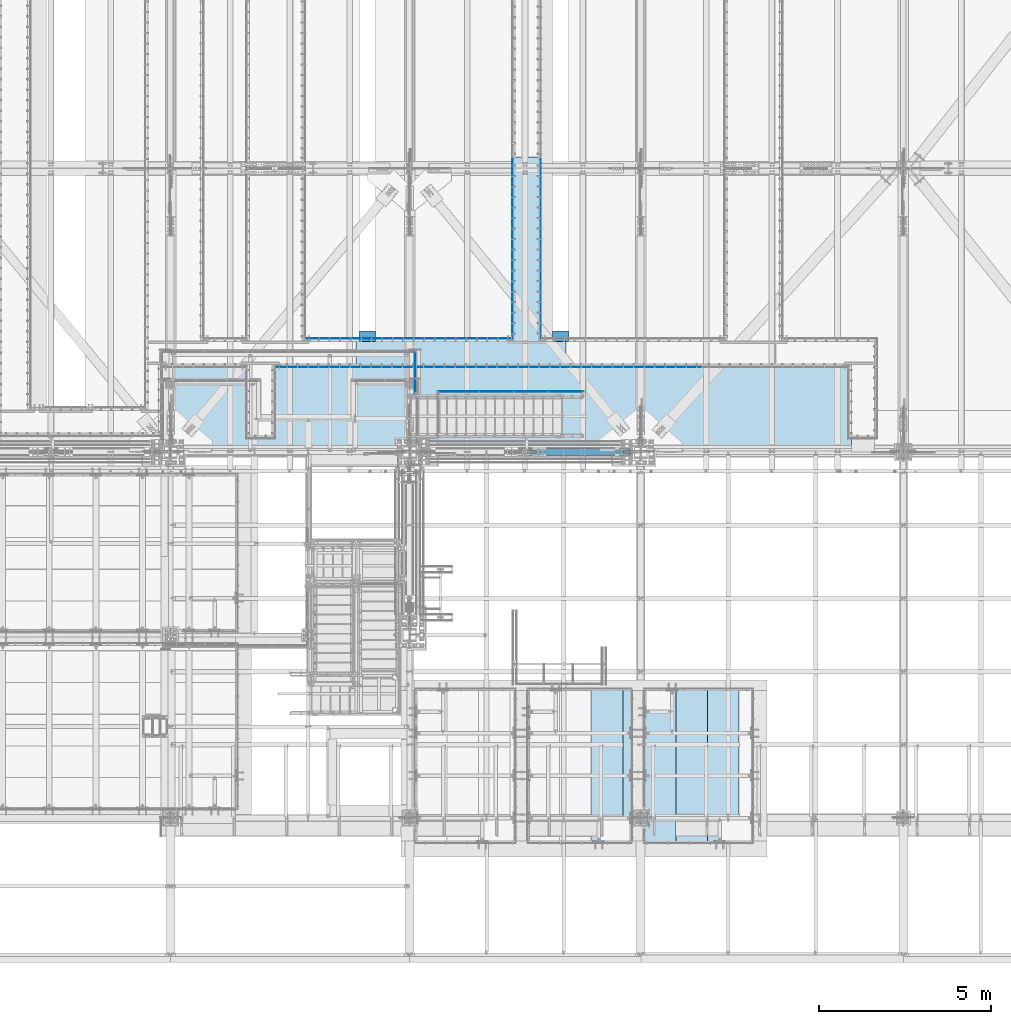
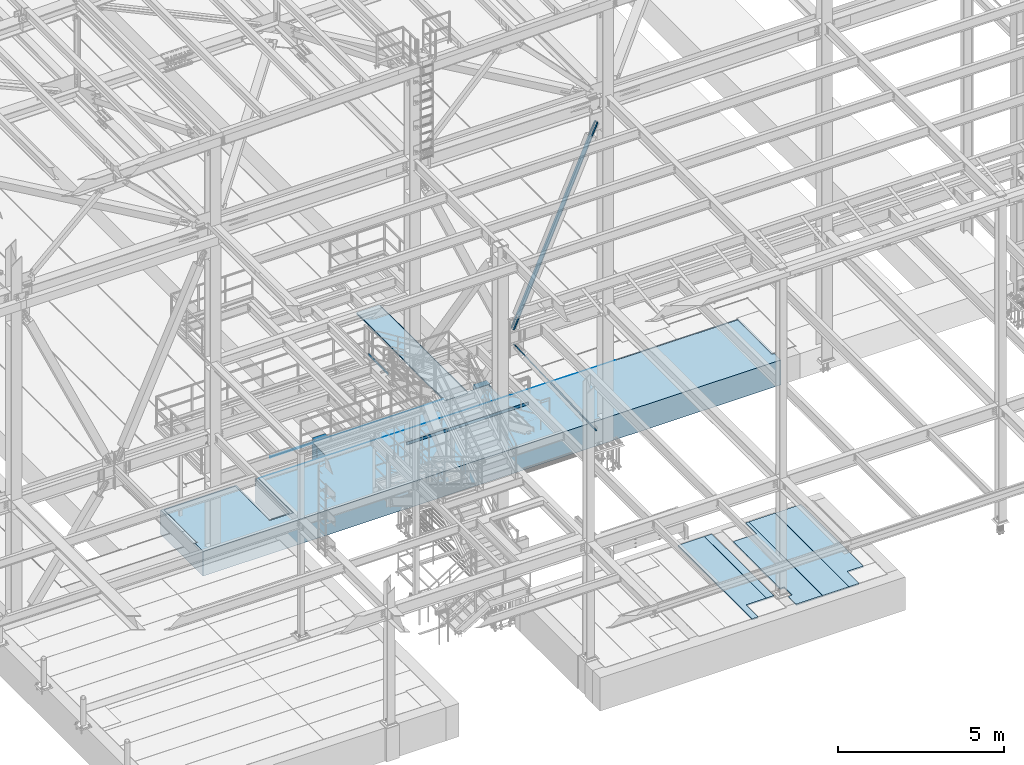
# One storey, part 2974 of 3843: 16 plates, 3 slabs, 19 elements without a shape of their own.
"""IFC2X3 building model written with IfcOpenShell, lengths in millimetres."""

from ifc_helpers import new_model, si_unit, frame, origin_with_axes, place, context, subcontext, project, spatial, faceted_brep, material, type_object, element, aggregate, save


model = new_model("IFC2X3")

# Units and contexts
model_context = context("Model", 3, precision=1e-05, world=origin_with_axes())
body_context = subcontext(model_context, "Body", "Model", "MODEL_VIEW")
ifc_project = project(units=[si_unit("LENGTHUNIT", "METRE", prefix="MILLI"), si_unit("AREAUNIT", "SQUARE_METRE"), si_unit("VOLUMEUNIT", "CUBIC_METRE"), si_unit("MASSUNIT", "GRAM", prefix="KILO"), si_unit("TIMEUNIT", "SECOND"), si_unit("PLANEANGLEUNIT", "RADIAN"), si_unit("SOLIDANGLEUNIT", "STERADIAN"), si_unit("THERMODYNAMICTEMPERATUREUNIT", "DEGREE_CELSIUS"), si_unit("LUMINOUSINTENSITYUNIT", "LUMEN")], contexts=[model_context])

# Site, building, storey
site_placement = place(None, origin_with_axes())
site = spatial("IfcSite", under=ifc_project, at=site_placement, CompositionType="ELEMENT")
building_placement = place(site_placement, origin_with_axes())
building = spatial("IfcBuilding", under=site, at=building_placement, Name="Undefined", CompositionType="ELEMENT")
storey_placement = place(building_placement, origin_with_axes())
storey = spatial("IfcBuildingStorey", under=building, at=storey_placement, Name="Undefined", CompositionType="ELEMENT", Elevation=0.0)

# Assembly, plate
assembly_1_placement = place(storey_placement, origin_with_axes())
assembly_1 = element("IfcElementAssembly", 1, at=assembly_1_placement, inside=storey, Name="EMBED_ANGLE", AssemblyPlace="NOTDEFINED", PredefinedType="RIGID_FRAME")
ifc_material_1 = material(Name="STEEL/A36")
plate_type_1 = type_object("IfcPlateType", PredefinedType="NOTDEFINED")
plate_1_placement = place(assembly_1_placement, frame((58916.1253603516, 28911.55, 30480.0000003815), z_axis=(-1.0, 0.0, 0.0), x_axis=(0.0, 0.0, -1.0)))
plate_1 = element("IfcPlate", 2, at=plate_1_placement, type_object=plate_type_1, material=ifc_material_1, Name="PLATE", context=body_context, shape_type="Brep", body=[
    faceted_brep([(1.52265056385659e-06, -6.34999999999854, 6019.86439569353), (20.6374996185295, -6.34999999999854, 6019.86439569353), (25.4000010834243, -1.58749999999782, 6024.62684008812), (25.4000007629365, 6.34999999999854, 6032.62681836113), (1.52587745105848e-06, 6.34999999999854, 6032.62681835941), (25.399999620462, -1.58749999999782, 7.93729924158106), (25.3999999999942, 6.34999999994034, 2.91038304567337e-11), (7.27595761418343e-12, 6.3499999046162, 0.0), (3.21233528666198e-09, -6.34999999999854, 12.6997316948182), (20.6374996185295, -6.34999999999854, 12.6997316948182)], [[[0, 1, 2, 3, 4]], [[3, 2, 5, 6]], [[4, 3, 6, 7]], [[0, 4, 7, 8]], [[1, 0, 8, 9]], [[2, 1, 9, 5]], [[8, 7, 6, 5, 9]]]),
])
aggregate(assembly_1, [plate_1])

assembly_2_placement = place(storey_placement, origin_with_axes())
assembly_2 = element("IfcElementAssembly", 3, at=assembly_2_placement, inside=storey, Name="EMBED_ANGLE", AssemblyPlace="NOTDEFINED", PredefinedType="RIGID_FRAME")
plate_2_placement = place(assembly_2_placement, frame((58319.1623417968, 28086.05, 30480.0000003815), z_axis=(1.0, 0.0, 0.0), x_axis=(0.0, 0.0, -1.0)))
plate_2 = element("IfcPlate", 4, at=plate_2_placement, type_object=plate_type_1, material=ifc_material_1, Name="PLATE", context=body_context, shape_type="Brep", body=[
    faceted_brep([(25.3999996185303, -1.58755373666645, 6096.00000000171), (20.6375003814719, -6.34999999999854, 6096.00000000139), (20.6375000381231, -6.35000000004948, 2.5465851649642e-11), (25.3999996185303, -1.58755373666645, 0.0), (0.0, -6.3499999046162, 0.0), (3.81471181754023e-07, -6.34999999999854, 6096.0), (3.81471181754023e-07, 6.34999999999854, 6096.0), (7.27595761418343e-12, 6.3499999046162, 0.0), (25.3999996185303, 6.34999999999854, 6096.00000000171), (25.3999999999942, 6.34999999994034, 2.91038304567337e-11)], [[[0, 1, 2, 3]], [[4, 5, 6, 7]], [[8, 9, 7, 6]], [[9, 8, 0, 3]], [[4, 7, 9, 3, 2]], [[5, 4, 2, 1]], [[8, 6, 5, 1, 0]]]),
])
aggregate(assembly_2, [plate_2])

assembly_3_placement = place(storey_placement, origin_with_axes())
assembly_3 = element("IfcElementAssembly", 5, at=assembly_3_placement, inside=storey, Name="EMBED_ANGLE", AssemblyPlace="NOTDEFINED", PredefinedType="RIGID_FRAME")
plate_3_placement = place(assembly_3_placement, frame((52019.9618659935, 28086.0499953656, 30479.9999999483), z_axis=(1.0, 0.0, 0.0), x_axis=(0.0, 0.0, -1.0)))
plate_3 = element("IfcPlate", 6, at=plate_3_placement, type_object=plate_type_1, material=ifc_material_1, Name="PLATE", context=body_context, shape_type="Brep", body=[
    faceted_brep([(25.3999991853416, 6.35000000279615, 6299.20047579872), (-5.17175067216158e-08, 6.35000000279615, 6299.20047579701), (-5.17175067216158e-08, -6.34999999720458, 6299.20047579697), (20.6374991853409, -6.34999999720458, 6299.20047579836), (25.3999991853416, -1.58750164185403, 6299.20047579869), (25.3999996185303, -1.58750000000873, 7.93749999998545), (25.3999999999942, 6.34999999994034, 2.91038304567337e-11), (7.27595761418343e-12, 6.3499999046162, 0.0), (0.0, -6.34999999999854, 12.6999998092651), (20.6374996185259, -6.34999999993306, 12.7000361935643)], [[[0, 1, 2, 3, 4]], [[0, 4, 5, 6]], [[1, 0, 6, 7]], [[2, 1, 7, 8]], [[3, 2, 8, 9]], [[4, 3, 9, 5]], [[8, 7, 6, 5, 9]]]),
])
aggregate(assembly_3, [plate_3])

assembly_4_placement = place(storey_placement, origin_with_axes())
assembly_4 = element("IfcElementAssembly", 7, at=assembly_4_placement, inside=storey, Name="EMBED_ANGLE", AssemblyPlace="NOTDEFINED", PredefinedType="RIGID_FRAME")
plate_4_placement = place(assembly_4_placement, frame((59735.212, 34112.072, 30479.9999992371), z_axis=(0.0, -1.0, 0.0), x_axis=(0.0, 0.0, -1.0)))
plate_4 = element("IfcPlate", 8, at=plate_4_placement, type_object=plate_type_1, material=ifc_material_1, Name="PLATE", context=body_context, shape_type="Brep", body=[
    faceted_brep([(25.3999996185303, -6.34999999999491, 2.91038304567337e-11), (0.0, -6.3499999046162, 0.0), (7.27595761418343e-12, 6.3499999046162, 0.0), (20.6374996185295, 6.35000000000218, -7.27595761418343e-12), (25.3999996185921, 1.58750000000146, 7.27595761418343e-11), (25.3999996185303, -6.34999999999854, 5206.87216112583), (3.81471181754023e-07, -6.34999999999854, 5206.87216112583), (3.80539859179407e-07, 6.34999999999854, 5194.17200461555), (20.6374984696922, 6.34999999999854, 5194.17200461555), (25.3999996185303, 1.58750000000146, 5198.93450449431)], [[[0, 1, 2, 3, 4]], [[1, 0, 5, 6]], [[2, 1, 6, 7]], [[3, 2, 7, 8]], [[4, 3, 8, 9]], [[0, 4, 9, 5]], [[8, 7, 6, 5, 9]]]),
])
aggregate(assembly_4, [plate_4])

assembly_5_placement = place(storey_placement, origin_with_axes())
assembly_5 = element("IfcElementAssembly", 9, at=assembly_5_placement, inside=storey, Name="EMBED_ANGLE", AssemblyPlace="NOTDEFINED", PredefinedType="RIGID_FRAME")
plate_5_placement = place(assembly_5_placement, frame((58909.7753603516, 34112.0723632812, 30479.9999992371), z_axis=(0.0, -1.0, 0.0), x_axis=(0.0, 0.0, -1.0)))
plate_5 = element("IfcPlate", 10, at=plate_5_placement, type_object=plate_type_1, material=ifc_material_1, Name="PLATE", context=body_context, shape_type="Brep", body=[
    faceted_brep([(0.0, -6.3499999046162, 0.0), (7.27595761418343e-12, 6.3499999046162, 0.0), (25.3999999999942, 6.34999999994034, 2.91038304567337e-11), (25.3999996185921, -1.5874999999869, 7.27595761418343e-11), (20.6375000381231, -6.35000000004948, 2.5465851649642e-11), (25.3999996185303, 6.34999999999854, 5206.87216112583), (25.3999996185303, -1.58750000000146, 5198.93466129912), (20.6374984696922, -6.34999999999854, 5194.17209466067), (3.80539859179407e-07, -6.34999999999854, 5194.17209466067), (3.81471181754023e-07, 6.34999999999854, 5206.87216112583)], [[[0, 1, 2, 3, 4]], [[3, 2, 5, 6]], [[4, 3, 6, 7]], [[0, 4, 7, 8]], [[1, 0, 8, 9]], [[2, 1, 9, 5]], [[8, 7, 6, 5, 9]]]),
])
aggregate(assembly_5, [plate_5])

assembly_6_placement = place(storey_placement, origin_with_axes())
assembly_6 = element("IfcElementAssembly", 11, at=assembly_6_placement, inside=storey, Name="PLATE", AssemblyPlace="NOTDEFINED", PredefinedType="RIGID_FRAME")
ifc_material_2 = material(Name="STEEL/A572-50")
plate_type_2 = type_object("IfcPlateType", PredefinedType="NOTDEFINED")
plate_6_placement = place(assembly_6_placement, frame((60468.6349275972, 28098.7500826257, 30467.3), z_axis=(-0.999999912959143, -0.000417230999984894, 0.0), x_axis=(-0.000417230999984844, 0.999999912959143, 0.0)))
plate_6 = element("IfcPlate", 12, at=plate_6_placement, type_object=plate_type_2, material=ifc_material_2, Name="PLATE", context=body_context, shape_type="Brep", body=[
    faceted_brep([(800.423698086717, -12.7000000000007, 742.550670866294), (800.423698086717, 12.7000000000007, 742.550670866294), (724.209809157896, 12.7000000000007, 742.582469666151), (724.209809157896, -12.7000000000007, 742.582469666151), (724.546285097833, 12.7000000000007, 1549.03239946976), (724.546285097833, -12.7000000000007, 1549.03239946976), (800.757282319526, -12.7000000000007, 1549.00060187641), (800.757282319526, 12.7000000000007, 1549.00060187641), (800.116545483274, -12.7000000000007, -3.78349795937538e-10), (0.0, -12.6999999999971, 0.0), (0.0, 12.6999999999971, 0.0), (800.116545483274, 12.7000000000007, -3.78349795937538e-10), (2.54349122596977, -12.7000000000007, 6095.99946936808), (2.54349122596977, 12.7000000000007, 6095.99946936808), (802.63798902107, -12.7000000000007, 6095.66570336676), (802.63798902107, 12.7000000000007, 6095.66570336676)], [[[0, 1, 2, 3]], [[3, 2, 4, 5]], [[6, 5, 4, 7]], [[8, 9, 10, 11]], [[9, 12, 13, 10]], [[12, 14, 15, 13]], [[15, 14, 6, 7]], [[2, 1, 11, 10, 13, 15, 7, 4]], [[8, 11, 1, 0]], [[14, 12, 9, 8, 0, 3, 5, 6]]]),
])
aggregate(assembly_6, [plate_6])

assembly_7_placement = place(storey_placement, origin_with_axes())
assembly_7 = element("IfcElementAssembly", 13, at=assembly_7_placement, inside=storey, Name="PLATE", AssemblyPlace="NOTDEFINED", PredefinedType="RIGID_FRAME")
plate_7_placement = place(assembly_7_placement, frame((58922.4753603516, 28825.8249999635, 30467.3), z_axis=(0.0, 1.0, 0.0), x_axis=(1.0, 0.0, 0.0)))
plate_7 = element("IfcPlate", 14, at=plate_7_placement, type_object=plate_type_2, material=ifc_material_2, Name="PLATE", context=body_context, shape_type="Brep", body=[
    faceted_brep([(0.0, -12.6999999999971, 0.0), (-0.00374845569604076, -12.7000000000007, 5346.57214066155), (-0.00374845569604076, 12.7000000000007, 5346.57214066155), (0.0, 12.6999999999971, 0.0), (800.036675107956, -12.7000000000007, 5346.57214066295), (800.036675107956, 12.7000000000007, 5346.57214066295), (800.036639650629, -12.7000000000007, 5.49334799870849e-10), (800.036639650629, 12.7000000000007, 5.49334799870849e-10)], [[[0, 1, 2, 3]], [[1, 4, 5, 2]], [[4, 6, 7, 5]], [[6, 0, 3, 7]], [[5, 7, 3, 2]], [[6, 4, 1, 0]]]),
])
aggregate(assembly_7, [plate_7])

assembly_8_placement = place(storey_placement, origin_with_axes())
assembly_8 = element("IfcElementAssembly", 15, at=assembly_8_placement, inside=storey, Name="RAIL", AssemblyPlace="NOTDEFINED", PredefinedType="RIGID_FRAME")
plate_type_3 = type_object("IfcPlateType", PredefinedType="NOTDEFINED")
plate_8_placement = place(assembly_8_placement, frame((56086.3749999435, 28517.85, 33312.1000002631), z_axis=(0.0, 0.0, 1.0), x_axis=(0.0, -1.0, 0.0)))
plate_8 = element("IfcPlate", 16, at=plate_8_placement, type_object=plate_type_3, material=ifc_material_2, Name="TOE_PLATE", context=body_context, shape_type="Brep", body=[
    faceted_brep([(0.0, -3.17499999999927, 0.0), (0.0, -3.17499999999927, 101.600000000006), (0.0, 3.17499999999927, 101.600000000006), (0.0, 3.17499999999927, 0.0), (1206.49999999741, -3.17500000000291, 101.599999999999), (1206.49999999741, 3.17500000000291, 101.599999999999), (1206.49999999741, -3.17500000000291, 0.0), (1206.49999999741, 3.17500000000291, 0.0)], [[[0, 1, 2, 3]], [[1, 4, 5, 2]], [[4, 6, 7, 5]], [[6, 0, 3, 7]], [[5, 7, 3, 2]], [[6, 4, 1, 0]]]),
])
aggregate(assembly_8, [plate_8])

assembly_9_placement = place(storey_placement, origin_with_axes())
assembly_9 = element("IfcElementAssembly", 17, at=assembly_9_placement, inside=storey, Name="RAIL", AssemblyPlace="NOTDEFINED", PredefinedType="RIGID_FRAME")
plate_9_placement = place(assembly_9_placement, frame((60979.0499999948, 27371.67500005, 30492.6999999739), z_axis=(0.0, 0.0, 1.0), x_axis=(-1.0, 0.0, 0.0)))
plate_9 = element("IfcPlate", 18, at=plate_9_placement, type_object=plate_type_3, material=ifc_material_1, Name="TOE_PLATE", context=body_context, shape_type="Brep", body=[
    faceted_brep([(0.0, -3.17499999999927, 0.0), (0.0, -3.17499999999927, 101.600000000006), (0.0, 3.17499999999927, 101.600000000006), (0.0, 3.17499999999927, 0.0), (4229.09999998636, -3.17499999999927, 101.599999999999), (4229.09999998636, 3.17499999999927, 101.599999999999), (4229.09999998636, -3.17499999999927, 0.0), (4229.09999998636, 3.17499999999927, 0.0)], [[[0, 1, 2, 3]], [[1, 4, 5, 2]], [[4, 6, 7, 5]], [[6, 0, 3, 7]], [[5, 7, 3, 2]], [[6, 4, 1, 0]]]),
])
aggregate(assembly_9, [plate_9])

assembly_10_placement = place(storey_placement, origin_with_axes())
assembly_10 = element("IfcElementAssembly", 19, at=assembly_10_placement, inside=storey, Name="CB", AssemblyPlace="NOTDEFINED", PredefinedType="RIGID_FRAME")
plate_type_4 = type_object("IfcPlateType", PredefinedType="NOTDEFINED")
plate_10_placement = place(assembly_10_placement, frame((62293.1418700081, 25712.7375, 30182.2289709), z_axis=(-0.564190505241422, 0.0, 0.825644641353306), x_axis=(0.0, -1.0, 0.0)))
plate_10 = element("IfcPlate", 20, at=plate_10_placement, type_object=plate_type_4, material=ifc_material_1, Name="CB", context=body_context, shape_type="Brep", body=[
    faceted_brep([(0.0, -12.7000000001135, 65.0875015259007), (0.0, -12.699999990713, 4902.99609687838), (0.0, 12.7000000092085, 4902.99609687839), (0.0, 12.6999999999025, 65.0875015259462), (4.95449104382351, -12.6999999906693, 4927.90400536637), (4.95449104382351, 12.7000000092521, 4927.90400536637), (19.0636878264413, -12.6999999906257, 4949.01991057782), (19.0636878264413, 12.7000000092958, 4949.01991057782), (40.1795930378867, -12.6999999905966, 4963.12910736044), (40.1795930378867, 12.7000000093249, 4963.12910736044), (65.0875000000015, -12.6999999905966, 4968.08359840425), (65.0875000000015, 12.7000000093394, 4968.08359840426), (65.0875000000015, -12.6999999915861, 4436.66679921074), (65.0875000000015, 12.7000000083353, 4436.66679921074), (128.587500000001, -12.6999999915861, 4436.66679921074), (128.587500000001, 12.7000000083353, 4436.66679921074), (128.587498474124, -12.6999999905966, 4968.08359840425), (128.587498474124, 12.7000000093394, 4968.08359840426), (153.495406962116, -12.6999999905966, 4963.12910736044), (153.495406962116, 12.7000000093249, 4963.12910736044), (174.611312173562, -12.6999999906257, 4949.01991057782), (174.611312173562, 12.7000000092958, 4949.01991057782), (188.720508956179, -12.6999999906693, 4927.90400536637), (188.720508956179, 12.7000000092521, 4927.90400536637), (193.675000000003, -12.699999990713, 4902.99609687838), (193.675000000003, 12.7000000092085, 4902.99609687839), (193.674999999988, -12.7000000001135, 65.0875015259007), (193.674999999988, 12.6999999999025, 65.0875015259462), (188.720508956161, -12.7000000000698, 40.1795930378939), (188.720508956161, 12.6999999999389, 40.1795930379376), (174.611312173554, -12.7000000000407, 19.0636878264304), (174.611312173554, 12.6999999999753, 19.0636878264741), (153.495406962102, -12.7000000000189, 4.9544910438035), (153.495406962102, 12.7000000000044, 4.95449104384716), (128.587499999994, -12.7000000000044, -2.00088834390044e-11), (128.587499999994, 12.7000000000116, 1.81898940354586e-11), (128.587499999994, -12.6999999980762, 531.416799185412), (128.587499999994, 12.7000000018015, 531.416799185514), (65.0874999999942, -12.6999999980762, 531.416799185412), (65.0874999999942, 12.7000000018015, 531.416799185514), (65.0875015258789, -12.7000000000044, -2.00088834390044e-11), (65.0875015258789, 12.7000000000116, 1.81898940354586e-11), (40.1795930378867, -12.7000000000189, 4.9544910438035), (40.1795930378867, 12.7000000000044, 4.95449104384716), (19.063687826434, -12.7000000000407, 19.0636878264304), (19.063687826434, 12.6999999999753, 19.0636878264741), (4.95449104382715, -12.7000000000698, 40.1795930378939), (4.95449104382715, 12.6999999999389, 40.1795930379376)], [[[0, 1, 2, 3]], [[1, 4, 5, 2]], [[4, 6, 7, 5]], [[6, 8, 9, 7]], [[8, 10, 11, 9]], [[10, 12, 13, 11]], [[12, 14, 15, 13]], [[14, 16, 17, 15]], [[16, 18, 19, 17]], [[18, 20, 21, 19]], [[20, 22, 23, 21]], [[22, 24, 25, 23]], [[24, 26, 27, 25]], [[26, 28, 29, 27]], [[28, 30, 31, 29]], [[30, 32, 33, 31]], [[32, 34, 35, 33]], [[34, 36, 37, 35]], [[36, 38, 39, 37]], [[38, 40, 41, 39]], [[40, 42, 43, 41]], [[42, 44, 45, 43]], [[44, 46, 47, 45]], [[46, 0, 3, 47]], [[5, 7, 9, 11, 13, 15, 17, 19, 21, 23, 25, 27, 29, 31, 33, 35, 37, 39, 41, 43, 45, 47, 3, 2]], [[46, 44, 42, 40, 38, 36, 34, 32, 30, 28, 26, 24, 22, 20, 18, 16, 14, 12, 10, 8, 6, 4, 1, 0]]]),
])
aggregate(assembly_10, [plate_10])

assembly_11_placement = place(storey_placement, origin_with_axes())
assembly_11 = element("IfcElementAssembly", 21, at=assembly_11_placement, inside=storey, Name="CB", AssemblyPlace="NOTDEFINED", PredefinedType="RIGID_FRAME")
plate_11_placement = place(assembly_11_placement, frame((59414.4510896862, 25519.0625, 34880.5602910284), z_axis=(0.403080846030053, 0.0, 0.915164374068231), x_axis=(0.0, 1.0, 0.0)))
plate_11 = element("IfcPlate", 22, at=plate_11_placement, type_object=plate_type_4, material=ifc_material_1, Name="CB", context=body_context, shape_type="Brep", body=[
    faceted_brep([(0.0, -12.7000000001135, 65.0875015259007), (0.0, -12.6999999967738, 7188.99609679334), (0.0, 12.7000000032567, 7188.99609679332), (0.0, 12.6999999999025, 65.0875015259462), (4.95449104382351, -12.6999999967666, 7213.90400528136), (4.95449104382351, 12.7000000032713, 7213.90400528136), (19.0636878264413, -12.699999996752, 7235.01991049284), (19.0636878264413, 12.7000000032858, 7235.01991049282), (40.1795930378867, -12.6999999967375, 7249.12910727547), (40.1795930378867, 12.7000000032858, 7249.12910727546), (65.0875000000015, -12.6999999967447, 7254.0835983193), (65.0875000000015, 12.7000000032931, 7254.08359831929), (65.0875000000015, -12.6999999969703, 6767.11679913235), (65.0875000000015, 12.7000000030675, 6767.11679913234), (128.587500000001, -12.6999999969703, 6767.11679913235), (128.587500000001, 12.7000000030675, 6767.11679913234), (128.587498474124, -12.6999999967447, 7254.0835983193), (128.587498474124, 12.7000000032931, 7254.08359831929), (153.495406962116, -12.6999999967375, 7249.12910727547), (153.495406962116, 12.7000000032858, 7249.12910727546), (174.611312173562, -12.699999996752, 7235.01991049284), (174.611312173562, 12.7000000032858, 7235.01991049282), (188.720508956179, -12.6999999967666, 7213.90400528136), (188.720508956179, 12.7000000032713, 7213.90400528136), (193.675000000003, -12.6999999967738, 7188.99609679334), (193.675000000003, 12.7000000032567, 7188.99609679332), (193.674999999988, -12.7000000001135, 65.0875015259007), (193.674999999988, 12.6999999999025, 65.0875015259462), (188.720508956161, -12.7000000000698, 40.1795930378939), (188.720508956161, 12.6999999999389, 40.1795930379376), (174.611312173554, -12.7000000000407, 19.0636878264304), (174.611312173554, 12.6999999999753, 19.0636878264741), (153.495406962102, -12.7000000000189, 4.9544910438035), (153.495406962102, 12.7000000000044, 4.95449104384716), (128.587499999994, -12.7000000000044, -2.00088834390044e-11), (128.587499999994, 12.7000000000116, 1.81898940354586e-11), (128.587499999994, -12.7000000008265, 486.966799195696), (128.587499999994, 12.6999999991895, 486.966799195738), (65.0874999999942, -12.7000000008265, 486.966799195696), (65.0874999999942, 12.6999999991895, 486.966799195738), (65.0875015258789, -12.7000000000044, -2.00088834390044e-11), (65.0875015258789, 12.7000000000116, 1.81898940354586e-11), (40.1795930378867, -12.7000000000189, 4.9544910438035), (40.1795930378867, 12.7000000000044, 4.95449104384716), (19.063687826434, -12.7000000000407, 19.0636878264304), (19.063687826434, 12.6999999999753, 19.0636878264741), (4.95449104382715, -12.7000000000698, 40.1795930378939), (4.95449104382715, 12.6999999999389, 40.1795930379376)], [[[0, 1, 2, 3]], [[1, 4, 5, 2]], [[4, 6, 7, 5]], [[6, 8, 9, 7]], [[8, 10, 11, 9]], [[10, 12, 13, 11]], [[12, 14, 15, 13]], [[14, 16, 17, 15]], [[16, 18, 19, 17]], [[18, 20, 21, 19]], [[20, 22, 23, 21]], [[22, 24, 25, 23]], [[24, 26, 27, 25]], [[26, 28, 29, 27]], [[28, 30, 31, 29]], [[30, 32, 33, 31]], [[32, 34, 35, 33]], [[34, 36, 37, 35]], [[36, 38, 39, 37]], [[38, 40, 41, 39]], [[40, 42, 43, 41]], [[42, 44, 45, 43]], [[44, 46, 47, 45]], [[46, 0, 3, 47]], [[5, 7, 9, 11, 13, 15, 17, 19, 21, 23, 25, 27, 29, 31, 33, 35, 37, 39, 41, 43, 45, 47, 3, 2]], [[46, 44, 42, 40, 38, 36, 34, 32, 30, 28, 26, 24, 22, 20, 18, 16, 14, 12, 10, 8, 6, 4, 1, 0]]]),
])
aggregate(assembly_11, [plate_11])

assembly_12_placement = place(storey_placement, origin_with_axes())
assembly_12 = element("IfcElementAssembly", 23, at=assembly_12_placement, inside=storey, Name="GRATING", AssemblyPlace="NOTDEFINED", PredefinedType="NOTDEFINED")
ifc_material_3 = material()
plate_type_5 = type_object("IfcPlateType", PredefinedType="NOTDEFINED")
plate_12_placement = place(assembly_12_placement, frame((64579.5000488281, 14277.9750712279, 30454.6), z_axis=(0.0, 1.0, 0.0), x_axis=(1.0, 0.0, 0.0)))
plate_12 = element("IfcPlate", 24, at=plate_12_placement, type_object=plate_type_5, material=ifc_material_3, Name="GRATING", context=body_context, shape_type="Brep", body=[
    faceted_brep([(346.07495117189, -25.4000000000015, -1.43700162880123e-10), (346.07495117189, 25.4000000000015, -1.43700162880123e-10), (346.074980125253, 25.4000000000015, 723.899864033301), (346.074980125253, -25.4000000000015, 723.899864033301), (914.400024411741, -25.4000000000015, 723.899841298235), (914.400024411741, 25.4000000000015, 723.899841298235), (0.0, -25.3999996185303, 0.0), (-6.198970368132e-07, -25.4000000000015, 4464.04980468751), (-6.198970368132e-07, 25.4000000000015, 4464.04980468751), (0.0, 25.3999996185303, 0.0), (914.400024399707, -25.4000000000015, 4464.04980468712), (914.400024399707, 25.4000000000015, 4464.04980468712)], [[[0, 1, 2, 3]], [[4, 3, 2, 5]], [[6, 7, 8, 9]], [[7, 10, 11, 8]], [[11, 10, 4, 5]], [[1, 9, 8, 11, 5, 2]], [[6, 9, 1, 0]], [[10, 7, 6, 0, 3, 4]]]),
])
aggregate(assembly_12, [plate_12])

assembly_13_placement = place(storey_placement, origin_with_axes())
assembly_13 = element("IfcElementAssembly", 25, at=assembly_13_placement, inside=storey, Name="GRATING", AssemblyPlace="NOTDEFINED", PredefinedType="NOTDEFINED")
plate_13_placement = place(assembly_13_placement, frame((63658.750024414, 14277.9750342834, 30454.6), z_axis=(0.0, 1.0, 0.0), x_axis=(1.0, 0.0, 0.0)))
plate_13 = element("IfcPlate", 26, at=plate_13_placement, type_object=plate_type_5, material=ifc_material_3, Name="GRATING", context=body_context, shape_type="Brep", body=[
    faceted_brep([(0.0, -25.3999996185303, 0.0), (-6.198970368132e-07, -25.4000000000015, 4464.04980468751), (-6.198970368132e-07, 25.4000000000015, 4464.04980468751), (0.0, 25.3999996185303, 0.0), (914.400024399707, -25.4000000000015, 4464.04980468712), (914.400024399707, 25.4000000000015, 4464.04980468712), (914.400024414062, -25.4000000000015, -3.78349795937538e-10), (914.400024414062, 25.4000000000015, -3.78349795937538e-10)], [[[0, 1, 2, 3]], [[1, 4, 5, 2]], [[4, 6, 7, 5]], [[6, 0, 3, 7]], [[5, 7, 3, 2]], [[6, 4, 1, 0]]]),
])
aggregate(assembly_13, [plate_13])

assembly_14_placement = place(storey_placement, origin_with_axes())
assembly_14 = element("IfcElementAssembly", 27, at=assembly_14_placement, inside=storey, Name="GRATING", AssemblyPlace="NOTDEFINED", PredefinedType="NOTDEFINED")
plate_14_placement = place(assembly_14_placement, frame((62738.0, 14277.975, 30454.6), z_axis=(0.0, 1.0, 0.0), x_axis=(1.0, 0.0, 0.0)))
plate_14 = element("IfcPlate", 28, at=plate_14_placement, type_object=plate_type_5, material=ifc_material_3, Name="GRATING", context=body_context, shape_type="Brep", body=[
    faceted_brep([(815.975178940651, -25.4000000000015, 3800.47496735803), (815.975178940651, 25.4000000000015, 3800.47496735803), (-5.27768861502409e-07, 25.4000000000015, 3800.47500000001), (-5.27768861502409e-07, -25.4000000000015, 3800.47500000001), (815.975205481227, -25.4000000000015, 4464.04977204554), (815.975205481234, 25.4000000000015, 4464.04980468716), (-3.83879705623258e-06, -25.4000000000015, 962.02497558594), (-3.83879705623258e-06, 25.4000000000015, 962.02497558594), (139.700039801734, 25.4000000000015, 962.02501122759), (139.700039801734, -25.4000000000015, 962.02501122759), (139.700023469188, 25.4000000000015, 479.425011227593), (139.700023469188, -25.4000000000015, 479.425011227593), (-6.65677362121642e-08, 25.4000000000015, 479.425016536488), (-6.65677362121642e-08, -25.4000000000015, 479.425016536488), (0.0, 25.3999996185303, 0.0), (0.0, -25.3999996185303, 0.0), (914.400024414062, -25.4000000000015, -3.78349795937538e-10), (914.400024414062, 25.4000000000015, -3.78349795937538e-10), (914.400024399707, -25.4000000000015, 4464.04980468712), (914.400024399707, 25.4000000000015, 4464.04980468712)], [[[0, 1, 2, 3]], [[4, 5, 1, 0]], [[6, 7, 8, 9]], [[9, 8, 10, 11]], [[11, 10, 12, 13]], [[14, 15, 13, 12]], [[16, 15, 14, 17]], [[18, 16, 17, 19]], [[3, 6, 9, 11, 13, 15, 16, 18, 4, 0]], [[7, 6, 3, 2]], [[19, 17, 14, 12, 10, 8, 7, 2, 1, 5]], [[18, 19, 5, 4]]]),
])
aggregate(assembly_14, [plate_14])

assembly_15_placement = place(storey_placement, origin_with_axes())
assembly_15 = element("IfcElementAssembly", 29, at=assembly_15_placement, inside=storey, Name="GRATING", AssemblyPlace="NOTDEFINED", PredefinedType="NOTDEFINED")
plate_15_placement = place(assembly_15_placement, frame((61201.3000488281, 14277.9750712279, 30454.6), z_axis=(0.0, 1.0, 0.0), x_axis=(1.0, 0.0, 0.0)))
plate_15 = element("IfcPlate", 30, at=plate_15_placement, type_object=plate_type_5, material=ifc_material_3, Name="GRATING", context=body_context, shape_type="Brep", body=[
    faceted_brep([(212.724963378896, -25.4000000000015, -8.9130480773747e-11), (212.724963378896, 25.4000000000015, -8.9130480773747e-11), (212.72500414143, 25.4000000000015, 723.899878588891), (212.72500414143, -25.4000000000015, 723.899878588891), (914.400004140938, -25.4000000000015, 723.899902333402), (914.400024411727, 25.4000000000015, 723.8999023334), (0.0, -25.3999996185303, 0.0), (-6.198970368132e-07, -25.4000000000015, 4464.04980468751), (-6.198970368132e-07, 25.4000000000015, 4464.04980468751), (0.0, 25.3999996185303, 0.0), (914.400024399707, -25.4000000000015, 4464.04980468712), (914.400024399707, 25.4000000000015, 4464.04980468712)], [[[0, 1, 2, 3]], [[4, 3, 2, 5]], [[6, 7, 8, 9]], [[7, 10, 11, 8]], [[11, 10, 4, 5]], [[1, 9, 8, 11, 5, 2]], [[6, 9, 1, 0]], [[10, 7, 6, 0, 3, 4]]]),
])
aggregate(assembly_15, [plate_15])

assembly_16_placement = place(storey_placement, origin_with_axes())
assembly_16 = element("IfcElementAssembly", 31, at=assembly_16_placement, inside=storey, Name="GRATING", AssemblyPlace="NOTDEFINED", PredefinedType="NOTDEFINED")
plate_type_6 = type_object("IfcPlateType", PredefinedType="NOTDEFINED")
plate_16_placement = place(assembly_16_placement, frame((62122.0500482964, 15001.8749935033, 30454.6), z_axis=(0.0, 1.0, 0.0), x_axis=(1.0, 0.0, 0.0)))
plate_16 = element("IfcPlate", 32, at=plate_16_placement, type_object=plate_type_6, material=ifc_material_3, Name="GRATING", context=body_context, shape_type="Brep", body=[
    faceted_brep([(0.0, -25.3999996185303, 0.0), (0.000146561702422332, -25.4000000000015, 3740.14990234376), (0.000146561702422332, 25.4000000000015, 3740.14990234376), (0.0, 25.3999996185303, 0.0), (260.350067139843, -25.4000000000015, 3740.14990234368), (260.350067139843, 25.4000000000015, 3740.14990234368), (260.349914550781, -25.4000000000015, -2.12821760214865e-10), (260.349914550781, 25.4000000000015, -2.12821760214865e-10)], [[[0, 1, 2, 3]], [[1, 4, 5, 2]], [[4, 6, 7, 5]], [[6, 0, 3, 7]], [[5, 7, 3, 2]], [[6, 4, 1, 0]]]),
])
aggregate(assembly_16, [plate_16])

# Assembly, slab
assembly_17_placement = place(storey_placement, origin_with_axes())
assembly_17 = element("IfcElementAssembly", 33, at=assembly_17_placement, inside=storey, Name="SLAB", AssemblyPlace="NOTDEFINED", PredefinedType="REINFORCEMENT_UNIT")
ifc_material_4 = material(Name="CONCRETE/3000")
slab_type_1 = type_object("IfcSlabType", PredefinedType="NOTDEFINED")
slab_1_placement = place(assembly_17_placement, frame((54934.6120305176, 29133.6730041504, 30022.8), z_axis=(0.0, -1.0, 0.0), x_axis=(-1.0, 0.0, 0.0)))
slab_1 = element("IfcSlab", 34, at=slab_1_placement, type_object=slab_type_1, material=ifc_material_4, Name="SLAB", PredefinedType="FLOOR", context=body_context, shape_type="Brep", body=[
    faceted_brep([(457.199981689453, -457.200000000001, 228.475499732576), (457.199981689453, -431.799999968713, 228.475499742741), (0.0, -431.799999968713, 228.475499742741), (0.0, -457.200000000001, 228.475499732576), (457.199981689453, -431.800000000007, 304.67300001016), (0.0, -431.800000000007, 304.673004150391), (457.199981689453, -457.200000000001, -3.63797880709171e-12), (0.0, -457.200000000001, 0.0), (0.0, 457.200000000001, 0.0), (457.199981689453, 457.200000000001, 0.0), (457.199981689453, 457.200000000001, 304.673004150391), (0.0, 457.200000000001, 304.673004150391)], [[[0, 1, 2, 3]], [[4, 5, 2, 1]], [[6, 7, 8, 9]], [[10, 9, 8, 11]], [[0, 6, 9, 10, 4, 1]], [[7, 6, 0, 3]], [[11, 8, 7, 3, 2, 5]], [[10, 11, 5, 4]]]),
])
aggregate(assembly_17, [slab_1])

assembly_18_placement = place(storey_placement, origin_with_axes())
assembly_18 = element("IfcElementAssembly", 35, at=assembly_18_placement, inside=storey, Name="SLAB", AssemblyPlace="NOTDEFINED", PredefinedType="REINFORCEMENT_UNIT")
slab_2_placement = place(assembly_18_placement, frame((60535.312, 29133.673, 30022.8), z_axis=(0.0, -1.0, 0.0), x_axis=(-1.0, 0.0, 0.0)))
slab_2 = element("IfcSlab", 36, at=slab_2_placement, type_object=slab_type_1, material=ifc_material_4, Name="SLAB", PredefinedType="FLOOR", context=body_context, shape_type="Brep", body=[
    faceted_brep([(457.199981689453, -457.200000000001, 228.475499732576), (457.199981689453, -431.799999968713, 228.475499742741), (0.0, -431.799999968713, 228.475499742741), (0.0, -457.200000000001, 228.475499732576), (457.199981689453, -431.800000000007, 304.67300001016), (0.0, -431.800000000007, 304.673004150391), (457.199981689453, -457.200000000001, -3.63797880709171e-12), (0.0, -457.200000000001, 0.0), (0.0, 457.200000000001, 0.0), (457.199981689453, 457.200000000001, 0.0), (457.199981689453, 457.200000000001, 304.673004150391), (0.0, 457.200000000001, 304.673004150391)], [[[0, 1, 2, 3]], [[4, 5, 2, 1]], [[6, 7, 8, 9]], [[10, 9, 8, 11]], [[0, 6, 9, 10, 4, 1]], [[7, 6, 0, 3]], [[11, 8, 7, 3, 2, 5]], [[10, 11, 5, 4]]]),
])
aggregate(assembly_18, [slab_2])

assembly_19_placement = place(storey_placement, origin_with_axes())
assembly_19 = element("IfcElementAssembly", 37, at=assembly_19_placement, inside=storey, Name="SLAB", AssemblyPlace="NOTDEFINED", PredefinedType="REINFORCEMENT_UNIT")
slab_type_2 = type_object("IfcSlabType", PredefinedType="NOTDEFINED")
slab_3_placement = place(assembly_19_placement, frame((48648.112, 28168.6, 30022.8), z_axis=(1.0, 0.0, 0.0), x_axis=(0.0, -1.0, 0.0)))
slab_3 = element("IfcSlab", 38, at=slab_3_placement, type_object=slab_type_2, material=ifc_material_4, Name="SLAB", PredefinedType="FLOOR", context=body_context, shape_type="Brep", body=[
    faceted_brep([(2079.62500584187, -431.800013153581, -3.19388491334394e-05), (2079.62500027929, -431.80001235599, 76.1999680586378), (76.2000002808709, -431.800000797659, 76.1998218092485), (76.1999992246492, -431.800001838892, 0.0), (2079.62500012691, -457.200012390706, 76.2001261084297), (2079.62500568949, -457.200000000001, 0.0), (76.2000003743742, -457.199999999873, 76.2000000108419), (2079.62500330107, 457.200000000001, 3295.65001401888), (2079.625, 457.200000000001, 2635.24998960157), (2079.625, -431.800000665007, 2635.24998960157), (2079.62500330107, -431.799999928073, 3295.65001401888), (0.0, 457.200000000001, 2635.24999999999), (0.0, 457.200000000001, 0.0), (0.0, -431.800000000287, 0.0), (0.0, -431.800000035561, 2635.24999999999), (76.2000002808709, -431.800000797659, 2635.24999961898), (76.2000002808672, -431.799983769411, 20104.0996217832), (0.0, -431.800000000014, 20104.099609375), (-3.63797880709171e-11, -431.800000762138, 20027.8998073659), (76.2000002808672, -431.799984531535, 20027.899812776), (2155.82499999996, -431.799541571367, 20027.8999604269), (2155.82499458985, -431.799540809243, 20104.0999604243), (2155.82500541016, -457.199540808437, 20027.8999604269), (76.200000281151, -457.200000034718, 20027.8998127761), (2155.82500000007, -457.199540809273, 20104.0997624126), (2552.69995117188, -457.200000000001, 20104.099609375), (2552.69995117188, 457.200000000001, 20104.099609375), (0.0, 457.200000000001, 20104.099609375), (0.0, 457.200000000001, 3295.65002441406), (0.0, -431.800000035561, 3295.65002441406), (76.2000002808709, -431.800000797659, 3295.65002403317), (76.2000002808709, -431.800000723582, 3371.84986599984), (76.200000281151, -457.200000000157, 3371.84986599984), (2155.82500463444, -431.800000639309, 3371.84974746153), (2155.82500463444, -457.199999876368, 3371.84974746153), (2155.82500029106, -431.799999928073, 3295.64989601408), (2155.82500029178, -457.199999928082, 3295.64990549468), (2155.82500010975, -431.800000588773, 2635.24999842721), (2155.82500028113, -457.20001251045, 2635.25015144234), (2155.82500584372, -457.20001251038, 2559.04999340596), (2155.8250059961, -431.800013273325, 2559.04999339506), (76.2000002808709, -431.800000797659, 2559.0498415831), (76.200000281151, -457.200000033714, 2559.04984159399), (2552.69995117188, 457.200000000001, 0.0), (2552.69995117188, -457.200000000001, 0.0)], [[[0, 1, 2, 3]], [[4, 1, 0, 5]], [[6, 2, 1, 4]], [[7, 8, 9, 10]], [[11, 12, 13, 14]], [[8, 11, 14, 15, 9]], [[16, 17, 18, 19, 20, 21]], [[22, 20, 19, 23]], [[24, 21, 20, 22]], [[25, 26, 27, 17, 16, 21, 24]], [[17, 27, 28, 29, 18]], [[19, 18, 29, 30, 31]], [[23, 19, 31, 32]], [[32, 31, 33, 34]], [[34, 33, 35, 36]], [[36, 35, 37, 38]], [[39, 40, 41, 42]], [[38, 37, 40, 39]], [[9, 15, 41, 40, 37]], [[35, 10, 9, 37]], [[33, 31, 30, 10, 35]], [[29, 28, 7, 10, 30]], [[27, 26, 43, 12, 11, 8, 7, 28]], [[25, 44, 43, 26]], [[3, 13, 12, 43, 44, 5, 0]], [[41, 15, 14, 13, 3, 2]], [[42, 41, 2, 6]], [[44, 25, 24, 22, 23, 32, 34, 36, 38, 39, 42, 6, 4, 5]]]),
])
aggregate(assembly_19, [slab_3])

save(model, "model.ifc")
